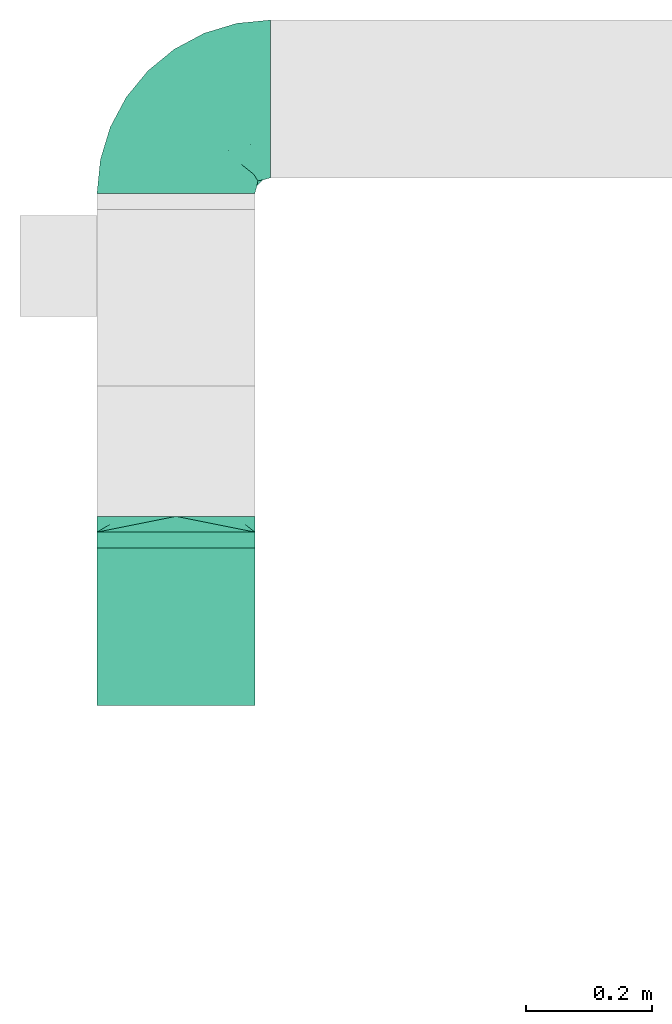
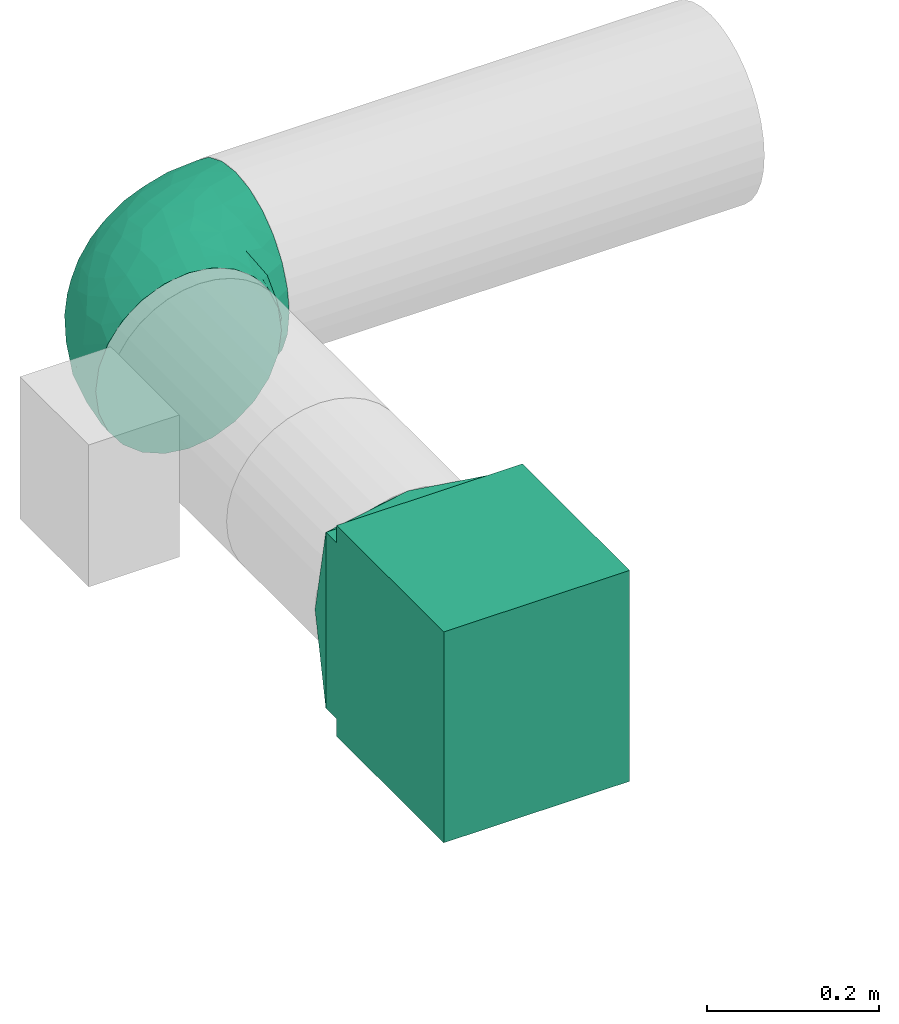
# One storey, part 3 of 4: 3 flow fittings.
"""IFC2X3 building model written with IfcOpenShell, lengths in millimetres."""

from ifc_helpers import new_model, entity, si_unit, converted_unit, derived_unit, direction, frame, origin, place, context, subcontext, project, spatial, polyline, outline, extrude, faceted_brep, source, transform, mapped, material, type_object, type_shapes, element, save


model = new_model("IFC2X3")

# Units and contexts
model_context = context("Model", 3, precision=0.01, world=origin(), true_north=direction((6.12303176911189e-17, 1.0)))
body_context = subcontext(model_context, "Body", "Model", "MODEL_VIEW")
ifc_project = project(units=[si_unit("LENGTHUNIT", "METRE", prefix="MILLI"), si_unit("AREAUNIT", "SQUARE_METRE"), si_unit("VOLUMEUNIT", "CUBIC_METRE"), converted_unit("PLANEANGLEUNIT", "DEGREE", entity("IfcRatioMeasure", 0.0174532925199433), si_unit("PLANEANGLEUNIT", "RADIAN"), dimensions=[0, 0, 0, 0, 0, 0, 0]), si_unit("MASSUNIT", "GRAM", prefix="KILO"), derived_unit("MASSDENSITYUNIT", [(si_unit("MASSUNIT", "GRAM", prefix="KILO"), 1), (si_unit("LENGTHUNIT", "METRE"), -3)]), si_unit("TIMEUNIT", "SECOND"), si_unit("FREQUENCYUNIT", "HERTZ"), si_unit("THERMODYNAMICTEMPERATUREUNIT", "DEGREE_CELSIUS"), derived_unit("THERMALTRANSMITTANCEUNIT", [(si_unit("MASSUNIT", "GRAM", prefix="KILO"), 1), (si_unit("THERMODYNAMICTEMPERATUREUNIT", "KELVIN"), -1), (si_unit("TIMEUNIT", "SECOND"), -3)]), derived_unit("VOLUMETRICFLOWRATEUNIT", [(si_unit("LENGTHUNIT", "METRE"), 3), (si_unit("TIMEUNIT", "SECOND"), -1)]), si_unit("ELECTRICCURRENTUNIT", "AMPERE"), si_unit("ELECTRICVOLTAGEUNIT", "VOLT"), si_unit("POWERUNIT", "WATT"), si_unit("FORCEUNIT", "NEWTON", prefix="KILO"), si_unit("ILLUMINANCEUNIT", "LUX"), si_unit("LUMINOUSFLUXUNIT", "LUMEN"), si_unit("LUMINOUSINTENSITYUNIT", "CANDELA"), derived_unit("USERDEFINED", [(si_unit("MASSUNIT", "GRAM", prefix="KILO"), -1), (si_unit("LENGTHUNIT", "METRE"), -2), (si_unit("TIMEUNIT", "SECOND"), 3), (si_unit("LUMINOUSFLUXUNIT", "LUMEN"), 1)]), derived_unit("LINEARVELOCITYUNIT", [(si_unit("LENGTHUNIT", "METRE"), 1), (si_unit("TIMEUNIT", "SECOND"), -1)]), si_unit("PRESSUREUNIT", "PASCAL"), derived_unit("USERDEFINED", [(si_unit("LENGTHUNIT", "METRE"), -2), (si_unit("MASSUNIT", "GRAM", prefix="KILO"), 1), (si_unit("TIMEUNIT", "SECOND"), -2)])], contexts=[model_context])

# Site, building, storey
site_placement = place(None, origin())
site = spatial("IfcSite", under=ifc_project, at=site_placement, CompositionType="ELEMENT")
building_placement = place(site_placement, origin())
building = spatial("IfcBuilding", under=site, at=building_placement, CompositionType="ELEMENT")
storey_placement = place(building_placement, frame((0.0, 0.0, 8000.0)))
storey = spatial("IfcBuildingStorey", under=building, at=storey_placement, Name="02 Level", CompositionType="ELEMENT", Elevation=8000.0)

# Flow fittings
duct_fitting_type_1 = type_object("IfcDuctFittingType", Name="Air_Elbow short_Circ", PredefinedType="NOTDEFINED")
shared_shape_1 = source(origin(), body_context, "Body", "Brep", [
    faceted_brep([(-150.0, -32.3523806378152, -120.740728286134), (-150.0, -62.5000000000001, -108.253175473055), (-150.0, -88.3883476483185, -88.3883476483184), (-150.0, -108.253175473055, -62.4999999999999), (-150.0, -120.740728286134, -32.3523806378151), (-150.0, -125.0, 0.0), (-150.0, -120.740728286133, 32.3523806378158), (-150.0, -108.253175473054, 62.5000000000006), (-150.0, -88.3883476483179, 88.3883476483189), (-150.0, -62.4999999999994, 108.253175473055), (-150.0, -47.426190318907, 114.496951879594), (-150.0, -32.3523806378145, 120.740728286134), (-150.0, 0.0, 125.0), (-150.0, 32.3523806378156, 120.740728286133), (-150.0, 62.5000000000004, 108.253175473055), (-150.0, 88.3883476483188, 88.3883476483181), (-150.0, 108.253175473055, 62.4999999999996), (-150.0, 120.740728286134, 32.3523806378147), (-150.0, 123.435651932551, 11.8824032670586), (-150.0, 125.0, 0.0), (-150.0, 123.435651957388, -11.8824030784058), (-150.0, 120.740728286133, -32.3523806378155), (-150.0, 108.253175473055, -62.5000000000003), (-150.0, 88.3883476483182, -88.3883476483186), (-150.0, 62.4999999999998, -108.253175473055), (-150.0, 32.3523806378149, -120.740728286134), (-150.0, 0.0, -125.0), (0.0, -150.0, -125.0), (32.3523806378157, -150.0, -120.740728286134), (62.5000000000006, -150.0, -108.253175473055), (88.3883476483191, -150.0, -88.3883476483186), (108.253175473056, -150.0, -62.5000000000003), (120.740728286134, -150.0, -32.3523806378155), (123.435651967915, -150.0, -11.882402998446), (125.0, -150.0, 0.0), (123.435651942407, -150.0, 11.8824031922038), (120.740728286134, -150.0, 32.3523806378147), (108.253175473056, -150.0, 62.4999999999996), (88.3883476483196, -150.0, 88.3883476483181), (62.5000000000013, -150.0, 108.253175473055), (32.3523806378164, -150.0, 120.740728286133), (0.0, -150.0, 125.0), (-32.3523806378137, -150.0, 120.740728286134), (-62.4999999999986, -150.0, 108.253175473055), (-88.3883476483171, -150.0, 88.3883476483189), (-108.253175473054, -150.0, 62.5000000000006), (-120.740728286133, -150.0, 32.3523806378158), (-125.0, -150.0, 0.0), (-120.740728286133, -150.0, -32.3523806378151), (-108.253175473054, -150.0, -62.4999999999999), (-88.3883476483177, -150.0, -88.3883476483184), (-62.4999999999993, -150.0, -108.253175473055), (-47.4261903189069, -150.0, -114.496951879594), (-32.3523806378144, -150.0, -120.740728286134), (61.5542541047513, 23.6180894533453, 0.0), (76.8166118284912, -4.34215934351885, 36.4784551593461), (78.654143383201, 2.78181408039032, 0.0), (-107.650286082481, 120.828917244489, 0.0), (-118.950410719399, 121.94188237809, 0.0), (-134.47520521655, 123.470941174946, 0.0), (-104.978291071801, 115.896211779269, 36.0762953828009), (-98.4001040789566, 53.9628430343128, 109.445004780609), (-72.3157335278814, 68.3433914970576, 94.5606631552989), (-104.893239881748, 80.8641300661028, 91.4382355521353), (-96.3501614455635, 119.715952110888, 0.0), (-9.85362544116063, -110.378344389653, 124.923923156167), (-42.4833938815038, -107.782088248638, 120.147094064889), (-86.153263795542, 100.695403874887, 61.7233478403087), (-65.0280946569744, 106.747383493999, 33.443557785531), (-74.6225764033372, 21.2831891292868, 119.356425571857), (-46.6576932994355, 45.2628664218306, 102.931281147801), (-72.3472176796021, -118.598046915095, 106.00707228478), (-30.181321363474, 90.8187429032163, 38.3247326160971), (-70.5561087725814, 111.891411775746, 0.0), (-122.641019976636, 101.950353756475, 70.1921456806148), (-116.029933078324, 22.4446697961388, 122.317161759311), (-3.87227453406602, 60.0293001979925, 66.4690229889152), (-6.5545406401204, 44.0646866272317, 85.350831949551), (31.0815829535711, 16.1832151821723, 80.3202993154639), (-124.863076426312, -35.02364091556, 120.752635411014), (-100.878102436648, -43.0002899009219, 120.764526140437), (-65.2460766604593, -23.6299006304857, 124.981338254694), (-108.839291442555, -9.81519021738238, 124.939227930759), (-40.0496486471489, -1.9751024241996, 120.175633139922), (-19.3649461243935, -39.6901954019144, 123.22697540265), (111.891411775747, -70.5561087725829, 0.0), (106.747383973922, -65.0280912143933, 33.4435522492635), (115.896212240375, -104.978289788922, 36.076293164084), (-128.779008055589, -97.2792215313154, 83.3343675755997), (-129.846276411156, -129.84627642804, 29.3795101662085), (-137.499999999999, -128.349364905389, 0.0), (-119.508978979081, -123.341462022577, 60.2918029167743), (-117.382833556128, -72.4228430829308, 106.251870907854), (-25.6262961621547, -80.1753214783878, 124.782747564482), (-131.548236956176, -110.790620858511, 65.1719471748524), (-35.2869113408269, 83.3156317546561, 59.3885364241187), (-8.79719392560859, 75.269004466267, 46.9066376982592), (80.8641305584726, -104.893240937849, 91.4382352904789), (53.9628368321699, -98.4001001508859, 109.445007566679), (22.4446672811422, -116.029929681511, 122.317162140699), (101.950355286479, -122.641017340516, 70.1921430199164), (-81.9960770469301, -82.9111806812523, 112.506499839482), (121.941882232658, -118.950409242795, 0.0), (54.4859475333804, -9.97269301512521, 77.8031341973232), (72.0838963385765, -41.0064832243528, 78.3617835611187), (71.251669566406, -11.4744102833441, 57.4040159418747), (5.67366256371018, 73.4168733312184, 25.8218410570659), (32.5558794954592, 52.5906940820025, 23.8275763366719), (23.6180894533467, 61.55425410475, 0.0), (-104.061743134415, -104.061741649423, 91.6204401768965), (100.695405783636, -86.1532561367086, 61.7233412541476), (85.8987630246562, -72.298942037013, 77.1305759551526), (21.2831826839793, -74.6225676704571, 119.356426312895), (45.2628557573736, -46.657677121917, 102.931282428265), (-128.349364905388, -137.5, 0.0), (-97.2792212827368, -128.779007172919, 83.3343682018964), (44.4543648263017, 44.4543648263003, 0.0), (-52.705139116163, -62.5335134626551, 123.521409265362), (-44.7620560995991, 104.066871440604, 0.0), (68.3433809087284, -72.3157185192085, 94.5606674302311), (16.162962522349, 57.6081885852494, 46.7813378836038), (39.0643086961098, 39.0643160658399, 42.9833221935425), (87.2978457655956, -45.1469719017519, 60.4141052051649), (-73.6770751262291, -45.4290804428845, 123.301126563982), (90.8187420929716, -30.1813146205812, 38.3247255432369), (104.066871440605, -44.7620560996006, 0.0), (91.3605074119029, -20.9901210096052, 0.0), (24.8419677176115, -18.7098050381526, 104.4628615233), (46.9444181295578, 18.5239913801244, 60.8208891980822), (-29.5778446799892, 20.3201363536925, 110.417514778129), (13.0080717069866, 10.2820614252128, 97.1887902869043), (-1.53394209146154, -80.1817000123714, 124.206375369784), (-65.4894356396677, 87.5368940232825, 72.0830916827234), (9.92439824324807, -37.6446897703782, 116.445568419899), (-3.04954297208558, -3.04952905280945, 110.823842282024), (2.7818140803917, 78.6541433831998, 0.0), (59.4075113977493, 18.3919768641063, 39.1397493302004), (-41.0065082221364, 72.0839038715865, 78.3617888442077), (-20.9901210096037, 91.3605074119017, 0.0), (119.715952110889, -96.3501614455651, 0.0), (-23.6299179988057, -65.2460778291534, -124.981338515222), (-62.5335140350356, -52.7051321522757, -123.521410009679), (-39.6901857853554, -19.3649451890522, -123.226974224734), (73.4168733742841, 5.67366166885961, -25.8218433127719), (52.5906917601974, 32.5558816629036, -23.8275777472421), (-110.378347073661, -9.85362190254904, -124.923923249535), (-35.0236472156293, -124.863059021426, -120.752634758897), (-107.782088925523, -42.4833910778036, -120.147094743061), (-65.0280943433708, 106.747382926782, -33.4435593699909), (-86.1532622275364, 100.695403598284, -61.7233476308542), (-104.978289397083, 115.896211531471, -36.0762952658108), (-129.846276430226, -129.846276387071, -29.3795102302433), (-110.790620399346, -131.548235360156, -65.1719489671012), (-128.779008894392, -97.2792211868359, -83.3343675827014), (-104.061744765902, -104.061740157582, -91.6204400852508), (-123.341462756194, -119.508979301124, -60.291801599493), (53.9628420250463, -98.4000971565888, -109.445004383699), (-82.9111719502085, -81.9960693312282, -112.50650546776), (-118.598049105409, -72.3472165670435, -106.007072416171), (-122.641019448242, 101.950353750649, -70.1921456050946), (-98.4001019855057, 53.9628440035923, -109.445003978822), (-104.893238223024, 80.8641303146933, -91.4382350282511), (80.8641292666627, -104.893234920637, -91.4382353967358), (-9.97270838371827, 54.485960500352, -77.8031316627462), (-41.0065049684125, 72.0839032542554, -78.3617877513776), (-11.4744255033641, 71.2516789045734, -57.4040162551542), (-4.34216444876671, 76.8166149897799, -36.4784554826068), (-80.1753222808587, -25.6262887954871, -124.782747920507), (-116.029931420384, 22.4446712385047, -122.317161393809), (45.2628607882706, -46.6576825738772, -102.931281121668), (68.3433887340013, -72.3157292909759, -94.5606641780198), (-9.8151830458522, -108.839262459516, -124.939228400111), (22.4446699556419, -116.029925989706, -122.317161437833), (-72.298953284581, 85.8987604849819, -77.1305835190378), (-97.2792209116865, -128.779005996318, -83.3343690779209), (-72.3157308447408, 68.3433918222031, -94.5606621128927), (-46.6576894105135, 45.2628676819038, -102.931279126956), (-72.422840670004, -117.382841409987, -106.251870399877), (21.2831853090833, -74.6225640045938, -119.356425105916), (101.950353353368, -122.641019823701, -70.1921462468134), (-43.0003002529277, -100.878091329174, -120.764524865091), (60.0292953493994, -3.87226817055985, -66.4690235395615), (44.0646797153192, -6.55452919959333, -85.3508306205825), (16.1832033989244, 31.0815970254922, -80.3202964529749), (100.695402688448, -86.1532621979624, -61.7233491707037), (106.747381524869, -65.0280939101863, -33.4435636729749), (115.896211010696, -104.978286786289, -36.0762955232767), (-1.97512261791953, -40.0496336831204, -120.175635225652), (75.2690016288807, -8.79719117487841, -46.9066400280846), (90.8187416032175, -30.181318578684, -38.3247323782698), (83.315631357607, -35.2869127496766, -59.388538235289), (39.0643108807276, 39.0643133486842, -42.9833232218422), (57.6081840561054, 16.162966744892, -46.7813401074288), (18.5239820708271, 46.9444270147629, -60.8208879439308), (-74.6225723501512, 21.2831916140966, -119.356424356291), (-45.1469861494655, 87.2978481709874, -60.4141116504016), (-45.4290965712264, -73.6770713110896, -123.301124768617), (-30.1813201883898, 90.818742779246, -38.3247313356157), (-18.7098212867178, 24.8419796072181, -104.462861687025), (20.3201251027192, -29.5778424846975, -110.417518980415), (10.2820459472016, 13.0080933749158, -97.1887865677227), (-80.1817048843535, -1.5339337664806, -124.206374751548), (87.5368918123803, -65.4894359750046, -72.0830947930252), (-37.6446965781717, 9.92440491577136, -116.445567816425), (-3.04953343548765, -3.04952712079592, -110.823838051094), (18.3919716152399, 59.4075155656008, -39.1397494553499), (72.083900742128, -41.0065066004899, -78.361791447751)], [[[0, 1, 2, 3, 4, 5, 6, 7, 8, 9, 10, 11, 12, 13, 14, 15, 16, 17, 18, 19, 20, 21, 22, 23, 24, 25, 26]], [[27, 28, 29, 30, 31, 32, 33, 34, 35, 36, 37, 38, 39, 40, 41, 42, 43, 44, 45, 46, 47, 48, 49, 50, 51, 52, 53]], [[54, 55, 56]], [[57, 58, 59, 19, 18, 17]], [[17, 16, 60]], [[61, 62, 63]], [[64, 57, 60]], [[65, 66, 42]], [[67, 68, 60]], [[63, 15, 14]], [[63, 14, 61]], [[69, 70, 61]], [[71, 44, 43]], [[68, 67, 72]], [[68, 73, 60]], [[74, 16, 15]], [[66, 71, 43]], [[12, 75, 13]], [[76, 77, 78]], [[79, 11, 10, 9]], [[80, 81, 82]], [[83, 81, 84]], [[85, 86, 87]], [[7, 88, 8]], [[6, 5, 89]], [[90, 89, 5]], [[46, 91, 89]], [[70, 62, 61]], [[8, 92, 9]], [[66, 65, 93]], [[94, 88, 7]], [[75, 69, 61]], [[72, 95, 96]], [[67, 60, 74]], [[38, 97, 39]], [[61, 14, 13]], [[98, 99, 40]], [[100, 38, 37]], [[101, 71, 66]], [[98, 40, 39]], [[36, 102, 87]], [[103, 104, 105]], [[97, 98, 39]], [[37, 36, 87]], [[106, 107, 108]], [[9, 92, 79]], [[35, 34, 102, 36]], [[101, 109, 71]], [[86, 110, 87]], [[110, 111, 97]], [[46, 89, 47]], [[112, 98, 113]], [[47, 89, 114]], [[7, 6, 94]], [[109, 91, 115]], [[108, 107, 116]], [[84, 81, 117]], [[46, 45, 91]], [[115, 45, 44]], [[68, 72, 118]], [[82, 12, 11]], [[119, 104, 113]], [[43, 42, 66]], [[42, 41, 65]], [[120, 121, 107]], [[110, 86, 122]], [[40, 99, 41]], [[12, 82, 75]], [[37, 87, 100]], [[117, 81, 123]], [[101, 123, 80]], [[109, 92, 88]], [[124, 125, 126]], [[113, 103, 127]], [[78, 128, 120]], [[129, 130, 77]], [[44, 71, 115]], [[101, 92, 109]], [[117, 66, 93]], [[99, 131, 65]], [[98, 97, 119]], [[110, 97, 100]], [[15, 63, 74]], [[95, 67, 132]], [[81, 69, 82]], [[69, 81, 83]], [[84, 133, 134]], [[65, 131, 93]], [[106, 108, 135]], [[96, 106, 72]], [[122, 111, 110]], [[54, 116, 136]], [[112, 113, 133]], [[127, 133, 113]], [[137, 70, 77]], [[134, 129, 83]], [[137, 76, 95]], [[127, 78, 130]], [[92, 101, 80]], [[117, 101, 66]], [[41, 99, 65]], [[112, 99, 98]], [[13, 75, 61]], [[69, 75, 82]], [[45, 115, 91]], [[109, 115, 71]], [[8, 88, 92]], [[91, 109, 94]], [[85, 125, 86]], [[138, 106, 135]], [[124, 86, 125]], [[87, 139, 85]], [[93, 84, 117]], [[131, 133, 84]], [[93, 131, 84]], [[112, 131, 99]], [[88, 94, 109]], [[89, 91, 94]], [[60, 57, 17]], [[139, 87, 102]], [[114, 89, 90]], [[94, 6, 89]], [[16, 74, 60]], [[67, 74, 63]], [[38, 100, 97]], [[110, 100, 87]], [[79, 92, 80]], [[79, 82, 11]], [[79, 80, 82]], [[107, 106, 120]], [[116, 107, 136]], [[98, 119, 113]], [[120, 106, 96]], [[138, 72, 106]], [[120, 96, 76]], [[95, 76, 96]], [[120, 76, 78]], [[77, 76, 137]], [[137, 95, 132]], [[95, 72, 67]], [[137, 132, 62]], [[132, 67, 63]], [[136, 121, 128]], [[128, 121, 120]], [[136, 128, 105]], [[103, 105, 128]], [[136, 105, 55]], [[124, 105, 122]], [[104, 103, 113]], [[78, 103, 128]], [[105, 124, 55]], [[107, 121, 136]], [[104, 119, 111]], [[97, 111, 119]], [[104, 111, 122]], [[104, 122, 105]], [[86, 124, 122]], [[63, 62, 132]], [[137, 62, 70]], [[117, 123, 101]], [[123, 81, 80]], [[70, 69, 129]], [[134, 83, 84]], [[83, 129, 69]], [[70, 129, 77]], [[127, 134, 133]], [[112, 133, 131]], [[134, 127, 130]], [[78, 127, 103]], [[134, 130, 129]], [[130, 78, 77]], [[138, 118, 72]], [[124, 126, 55]], [[64, 60, 73]], [[68, 118, 73]], [[136, 55, 54]], [[56, 55, 126]], [[140, 141, 142]], [[143, 144, 54]], [[0, 26, 145]], [[146, 53, 52, 51]], [[0, 147, 1]], [[148, 149, 150]], [[5, 151, 90]], [[49, 48, 152]], [[153, 154, 155]], [[144, 116, 54]], [[3, 2, 153]], [[156, 29, 28]], [[157, 158, 147]], [[3, 155, 4]], [[21, 150, 22]], [[158, 2, 1]], [[20, 19, 59, 58, 21]], [[22, 150, 159]], [[160, 24, 161]], [[162, 30, 29]], [[24, 23, 161]], [[163, 164, 165]], [[159, 23, 22]], [[108, 166, 135]], [[147, 145, 167]], [[160, 25, 24]], [[25, 160, 168]], [[157, 154, 158]], [[169, 170, 156]], [[114, 90, 151]], [[27, 171, 172]], [[151, 48, 47]], [[149, 173, 161]], [[152, 174, 49]], [[175, 164, 176]], [[51, 177, 146]], [[49, 174, 50]], [[1, 147, 158]], [[27, 172, 28]], [[172, 178, 156]], [[179, 31, 30]], [[180, 140, 171]], [[181, 182, 183]], [[51, 50, 177]], [[171, 27, 53]], [[25, 168, 26]], [[156, 178, 169]], [[184, 185, 186]], [[187, 140, 142]], [[188, 189, 190]], [[145, 147, 0]], [[156, 162, 29]], [[189, 185, 184]], [[191, 192, 193]], [[186, 139, 102]], [[186, 102, 32]], [[4, 155, 151]], [[32, 31, 186]], [[194, 160, 176]], [[162, 156, 170]], [[126, 189, 143]], [[73, 148, 150]], [[185, 85, 186]], [[151, 47, 114]], [[184, 186, 179]], [[149, 148, 195]], [[196, 140, 180]], [[157, 196, 180]], [[154, 177, 174]], [[197, 148, 118]], [[176, 163, 198]], [[193, 163, 165]], [[199, 200, 182]], [[2, 158, 153]], [[157, 177, 154]], [[141, 147, 167]], [[168, 201, 145]], [[160, 161, 175]], [[149, 161, 159]], [[30, 162, 179]], [[190, 184, 202]], [[140, 178, 171]], [[178, 140, 187]], [[142, 203, 204]], [[145, 201, 167]], [[143, 54, 56]], [[188, 143, 189]], [[195, 173, 149]], [[108, 116, 205]], [[194, 176, 203]], [[198, 203, 176]], [[206, 169, 182]], [[204, 199, 187]], [[206, 181, 190]], [[198, 183, 200]], [[177, 157, 180]], [[141, 157, 147]], [[26, 168, 145]], [[194, 168, 160]], [[28, 172, 156]], [[178, 172, 171]], [[3, 153, 155]], [[154, 153, 158]], [[50, 174, 177]], [[155, 154, 152]], [[73, 118, 148]], [[139, 186, 85]], [[197, 138, 166]], [[150, 64, 73]], [[167, 142, 141]], [[201, 203, 142]], [[167, 201, 142]], [[194, 201, 168]], [[174, 152, 154]], [[151, 155, 152]], [[150, 58, 57, 64]], [[58, 150, 21]], [[102, 34, 33, 32]], [[152, 48, 151]], [[5, 4, 151]], [[31, 179, 186]], [[184, 179, 162]], [[23, 159, 161]], [[149, 159, 150]], [[146, 177, 180]], [[146, 171, 53]], [[146, 180, 171]], [[192, 191, 144]], [[205, 116, 144]], [[143, 192, 144]], [[192, 143, 188]], [[126, 125, 189]], [[192, 188, 181]], [[190, 181, 188]], [[192, 181, 183]], [[182, 181, 206]], [[206, 190, 202]], [[190, 189, 184]], [[206, 202, 170]], [[202, 184, 162]], [[160, 175, 176]], [[205, 191, 193]], [[165, 205, 193]], [[183, 193, 192]], [[205, 165, 166]], [[197, 165, 195]], [[164, 163, 176]], [[183, 163, 193]], [[165, 197, 166]], [[144, 191, 205]], [[164, 175, 173]], [[161, 173, 175]], [[164, 173, 195]], [[164, 195, 165]], [[148, 197, 195]], [[162, 170, 202]], [[206, 170, 169]], [[196, 141, 140]], [[141, 196, 157]], [[169, 178, 199]], [[204, 187, 142]], [[187, 199, 178]], [[169, 199, 182]], [[198, 204, 203]], [[194, 203, 201]], [[204, 198, 200]], [[183, 198, 163]], [[204, 200, 199]], [[200, 183, 182]], [[185, 189, 125]], [[126, 143, 56]], [[197, 118, 138]], [[185, 125, 85]], [[205, 166, 108]], [[135, 166, 138]]]),
])
type_shapes(duct_fitting_type_1, [shared_shape_1])
flow_fitting_1_placement = place(storey_placement, frame((25195.9632723171, -67405.0175280858, 3510.0), z_axis=(0.0, 0.0, 1.0), x_axis=(0.0, 1.0, 0.0)))
element("IfcFlowFitting", 1, at=flow_fitting_1_placement, inside=storey, type_object=duct_fitting_type_1, Name="elbow_short_001:Air_Elbow short_Circ", ObjectType="elbow_short_001:Air_Elbow short_Circ", context=body_context, shape_type="MappedRepresentation", body=[
    mapped(shared_shape_1, transform((0.0, 0.0, 0.0), scale=1.0)),
])
duct_fitting_type_2 = type_object("IfcDuctFittingType", Name="Air_Rect", PredefinedType="NOTDEFINED")
shared_shape_2 = source(origin(), body_context, "Body", "SweptSolid", [
    extrude(outline(polyline([(-56.2499999999996, -150.0), (193.75, -150.0), (193.75, 150.0), (-56.2500000000005, 150.0), (-56.2500000000004, 125.0), (-81.2499999999999, 125.0), (-81.2499999999999, -125.0), (-56.2499999999996, -125.0), (-56.2499999999996, -150.0)])), frame((0.0, 68.75, -125.0), z_axis=(0.0, 0.0, 1.0), x_axis=(0.0, -1.0, 0.0)), (0.0, 0.0, 1.0), 250.0),
])
type_shapes(duct_fitting_type_2, [shared_shape_2])
flow_fitting_2_placement = place(storey_placement, frame((25195.9632723171, -68241.2395851399, 3510.0), z_axis=(1.0, 0.0, 0.0), x_axis=(0.0, 0.0, -1.0)))
element("IfcFlowFitting", 2, at=flow_fitting_2_placement, inside=storey, type_object=duct_fitting_type_2, Name="1_001:Air_Rect", ObjectType="1_001:Air_Rect", context=body_context, shape_type="MappedRepresentation", body=[
    mapped(shared_shape_2, transform((0.0, 0.0, 0.0), scale=1.0)),
])
ifc_material = material(Name="Material_Duct")
duct_fitting_type_3 = type_object("IfcDuctFittingType", Name="Air_Multi shape transition_Circ", PredefinedType="NOTDEFINED", material=ifc_material)
shared_shape_3 = source(origin(), body_context, "Body", "Brep", [
    faceted_brep([(25.0, 38.627124296869, -118.882064536893), (25.0, 56.0501404167142, -110.00459441688), (25.0, 73.4731565365595, -101.127124296867), (25.0, 87.3001404167141, -87.3001404167125), (25.0, 101.127124296869, -73.4731565365578), (25.0, 110.004594416882, -56.0501404167124), (25.0, 118.882064536894, -38.6271242968671), (25.0, 121.223496625785, -23.8439038991246), (25.0, 123.111748312892, -11.9219519495616), (25.0, 124.055874156446, -5.96097597478013), (25.0, 125.0, 0.0), (25.0, 124.055874155635, 5.96097597990369), (25.0, 123.11174831127, 11.9219519598073), (25.0, 121.22349662254, 23.8439039196147), (25.0, 118.882064536894, 38.6271242968685), (25.0, 110.004594416881, 56.0501404167139), (25.0, 101.127124296868, 73.4731565365593), (25.0, 87.3001404167137, 87.3001404167139), (25.0, 73.473156536559, 101.127124296869), (25.0, 56.0501404167136, 110.004594416881), (25.0, 38.6271242968682, 118.882064536894), (25.0, 23.8439038991258, 121.223496625785), (25.0, 11.9219519495628, 123.111748312892), (25.0, 5.96097597478125, 124.055874156446), (25.0, 0.0, 125.0), (25.0, -5.96097597990388, 124.055874155635), (25.0, -11.9219519598075, 123.11174831127), (25.0, -23.8439039196148, 121.22349662254), (25.0, -38.6271242968687, 118.882064536894), (25.0, -56.050140416714, 110.004594416881), (25.0, -73.4731565365594, 101.127124296868), (25.0, -87.300140416714, 87.3001404167136), (25.0, -101.127124296869, 73.4731565365589), (25.0, -110.004594416881, 56.0501404167135), (25.0, -118.882064536894, 38.6271242968681), (25.0, -121.223496625785, 23.8439038991257), (25.0, -123.111748312893, 11.9219519495627), (25.0, -124.055874156446, 5.96097597478117), (25.0, -125.0, 0.0), (25.0, -124.055874155635, -5.96097597990274), (25.0, -123.11174831127, -11.9219519598064), (25.0, -121.22349662254, -23.8439039196137), (25.0, -118.882064536894, -38.6271242968675), (25.0, -110.004594416881, -56.0501404167129), (25.0, -101.127124296868, -73.4731565365583), (25.0, -87.3001404167137, -87.3001404167129), (25.0, -73.4731565365591, -101.127124296868), (25.0, -56.0501404167137, -110.00459441688), (25.0, -38.6271242968683, -118.882064536893), (25.0, -23.8439038991258, -121.223496625784), (25.0, -11.9219519495628, -123.111748312892), (25.0, -5.9609759747813, -124.055874156445), (25.0, 0.0, -125.0), (25.0, 5.96097597990422, -124.055874155634), (25.0, 11.9219519598079, -123.111748311269), (25.0, 23.8439039196152, -121.223496622539), (0.0, -125.0, -125.0), (0.0, -125.0, 125.0), (0.0, 125.0, 125.0), (0.0, 125.0, -125.0), (13.0142783389037, 59.9286083054818, 125.0), (3.25356958472593, 108.732152076371, 125.0), (12.4999999334883, 103.93826768006, 109.288032538106), (16.0107087541778, 44.9464562291113, 125.0), (19.0071391694519, 29.9643041527408, 125.0), (22.0035695847259, 14.9821520763703, 125.0), (23.501784792363, 7.49107603818503, 125.0), (6.50713897169544, 125.0, 92.464305141524), (3.25356948584772, 125.0, 108.732152570763), (9.76070845754316, 125.0, 76.1964577122852), (13.0142779433909, 125.0, 59.9286102830464), (23.5017847429239, 125.0, 7.49107628538083), (22.0035694858477, 125.0, 14.9821525707616), (19.0071389716954, 125.0, 29.9643051415232), (16.0107084575432, 125.0, 44.9464577122848), (6.50713916945185, 92.4643041527413, 125.0), (9.76070875417778, 76.1964562291116, 125.0), (23.501784792363, 125.0, -7.49107603818391), (22.0035695847259, 125.0, -14.9821520763692), (19.0071391694518, 125.0, -29.9643041527398), (16.0107087541778, 125.0, -44.9464562291103), (13.0142783389037, 125.0, -59.9286083054808), (9.76070875417777, 125.0, -76.1964562291106), (6.50713916945185, 125.0, -92.4643041527404), (3.25356958472592, 125.0, -108.73215207637), (12.4999999334883, 109.288032538106, -103.938267680059), (6.50713897169543, 92.4643051415237, -125.0), (3.25356948584772, 108.732152570762, -125.0), (9.76070845754315, 76.196457712285, -125.0), (13.0142779433909, 59.9286102830464, -125.0), (23.5017847429239, 7.49107628538129, -125.0), (22.0035694858477, 14.982152570762, -125.0), (19.0071389716954, 29.9643051415235, -125.0), (16.0107084575431, 44.9464577122849, -125.0), (23.501784792363, -7.49107603818498, -125.0), (22.0035695847259, -14.9821520763701, -125.0), (19.0071391694519, -29.9643041527404, -125.0), (16.0107087541778, -44.9464562291108, -125.0), (13.0142783389037, -59.9286083054811, -125.0), (9.76070875417778, -76.1964562291107, -125.0), (6.50713916945185, -92.4643041527402, -125.0), (3.25356958472593, -108.73215207637, -125.0), (12.4999999334883, -103.938267680059, -109.288032538105), (6.50713897169544, -125.0, -92.4643051415225), (3.25356948584772, -125.0, -108.732152570761), (9.76070845754316, -125.0, -76.1964577122838), (13.0142779433909, -125.0, -59.9286102830451), (23.5017847429239, -125.0, -7.49107628537984), (22.0035694858477, -125.0, -14.9821525707606), (19.0071389716954, -125.0, -29.9643051415221), (16.0107084575432, -125.0, -44.9464577122836), (23.501784792363, -125.0, 7.49107603818499), (22.0035695847259, -125.0, 14.9821520763703), (19.0071391694519, -125.0, 29.9643041527409), (16.0107087541778, -125.0, 44.9464562291115), (13.0142783389037, -125.0, 59.9286083054821), (9.76070875417777, -125.0, 76.196456229112), (6.50713916945185, -125.0, 92.4643041527418), (3.25356958472593, -125.0, 108.732152076372), (12.4999999334883, -109.288032538105, 103.93826768006), (6.50713897169544, -92.4643051415224, 125.0), (3.25356948584772, -108.732152570761, 125.0), (9.76070845754316, -76.1964577122839, 125.0), (13.0142779433909, -59.9286102830454, 125.0), (23.5017847429239, -7.49107628538088, 125.0), (22.0035694858477, -14.9821525707615, 125.0), (19.0071389716954, -29.9643051415228, 125.0), (16.0107084575432, -44.9464577122841, 125.0)], [[[0, 1, 2, 3, 4, 5, 6, 7, 8, 9, 10, 11, 12, 13, 14, 15, 16, 17, 18, 19, 20, 21, 22, 23, 24, 25, 26, 27, 28, 29, 30, 31, 32, 33, 34, 35, 36, 37, 38, 39, 40, 41, 42, 43, 44, 45, 46, 47, 48, 49, 50, 51, 52, 53, 54, 55]], [[56, 57, 58, 59]], [[20, 19, 60]], [[61, 62, 58]], [[60, 63, 64, 65, 66, 24, 23, 22, 21, 20]], [[67, 68, 16]], [[18, 62, 61]], [[69, 67, 15, 70]], [[13, 12, 11, 10, 71, 72, 73, 74, 70, 14]], [[19, 18, 75]], [[76, 60, 19, 75]], [[15, 14, 70]], [[17, 68, 62]], [[61, 75, 18]], [[17, 16, 68]], [[17, 62, 18]], [[68, 58, 62]], [[16, 15, 67]], [[77, 78, 79, 80, 81, 82, 83, 84, 59, 58, 68, 67, 69, 70, 74, 73, 72, 71, 10]], [[6, 5, 81]], [[84, 85, 59]], [[81, 80, 79, 78, 77, 10, 9, 8, 7, 6]], [[86, 87, 2]], [[4, 85, 84]], [[88, 86, 1, 89]], [[55, 54, 53, 52, 90, 91, 92, 93, 89, 0]], [[5, 4, 83]], [[82, 81, 5, 83]], [[1, 0, 89]], [[3, 87, 85]], [[84, 83, 4]], [[3, 2, 87]], [[3, 85, 4]], [[87, 59, 85]], [[2, 1, 86]], [[56, 59, 87, 86, 88, 89, 93, 92, 91, 90, 52, 94, 95, 96, 97, 98, 99, 100, 101]], [[48, 47, 98]], [[101, 102, 56]], [[98, 97, 96, 95, 94, 52, 51, 50, 49, 48]], [[103, 104, 44]], [[46, 102, 101]], [[105, 103, 43, 106]], [[41, 40, 39, 38, 107, 108, 109, 110, 106, 42]], [[47, 46, 100]], [[99, 98, 47, 100]], [[43, 42, 106]], [[45, 104, 102]], [[101, 100, 46]], [[45, 44, 104]], [[45, 102, 46]], [[104, 56, 102]], [[44, 43, 103]], [[111, 112, 113, 114, 115, 116, 117, 118, 57, 56, 104, 103, 105, 106, 110, 109, 108, 107, 38]], [[34, 33, 115]], [[118, 119, 57]], [[115, 114, 113, 112, 111, 38, 37, 36, 35, 34]], [[120, 121, 30]], [[32, 119, 118]], [[122, 120, 29, 123]], [[27, 26, 25, 24, 124, 125, 126, 127, 123, 28]], [[33, 32, 117]], [[116, 115, 33, 117]], [[29, 28, 123]], [[31, 121, 119]], [[118, 117, 32]], [[31, 30, 121]], [[31, 119, 32]], [[121, 57, 119]], [[30, 29, 120]], [[66, 65, 64, 63, 60, 76, 75, 61, 58, 57, 121, 120, 122, 123, 127, 126, 125, 124, 24]]]),
])
type_shapes(duct_fitting_type_3, [shared_shape_3])
flow_fitting_3_placement = place(storey_placement, frame((25195.9632723171, -68091.2395851399, 3510.0), z_axis=(0.0, 0.0, 1.0), x_axis=(0.0, 1.0, 0.0)))
element("IfcFlowFitting", 3, at=flow_fitting_3_placement, inside=storey, type_object=duct_fitting_type_3, material=ifc_material, Name="multi_shape_trans_001:Air_Multi shape transition_Circ", ObjectType="multi_shape_trans_001:Air_Multi shape transition_Circ", context=body_context, shape_type="MappedRepresentation", body=[
    mapped(shared_shape_3, transform((0.0, 0.0, 0.0), scale=1.0)),
])

save(model, "model.ifc")
